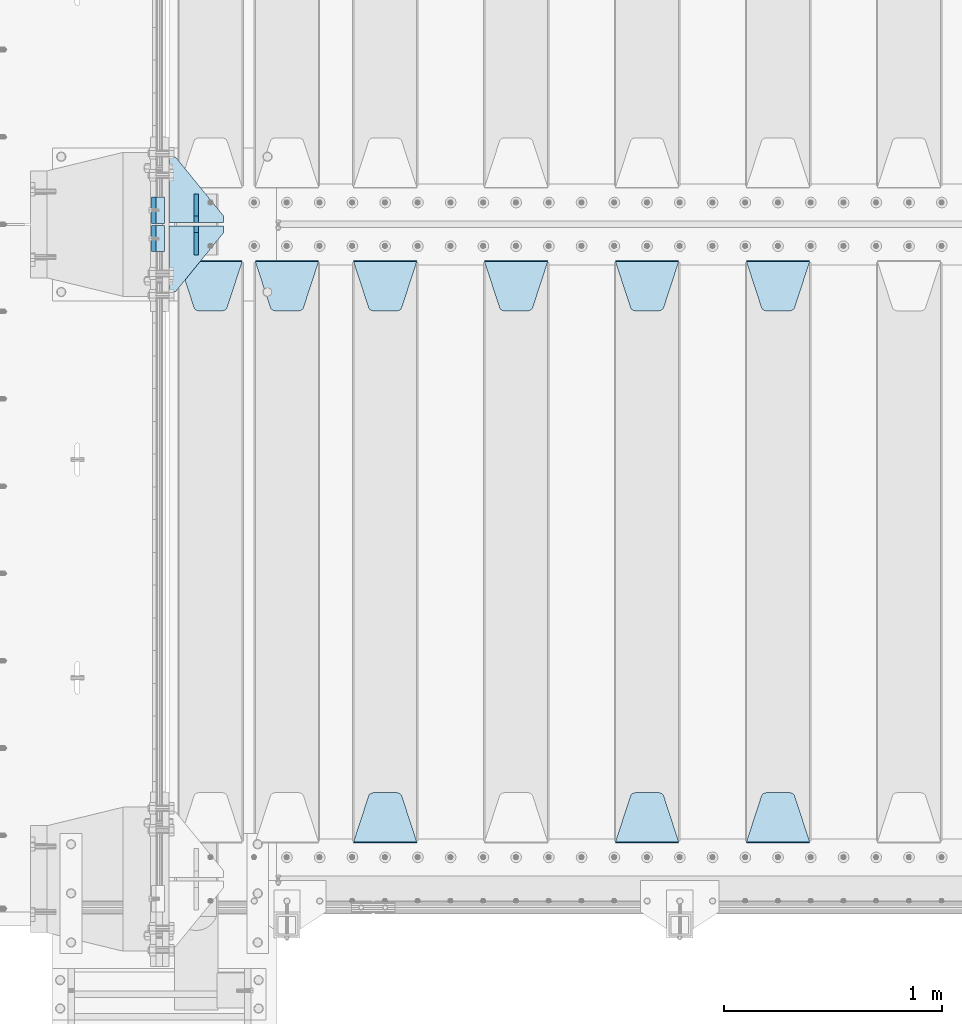
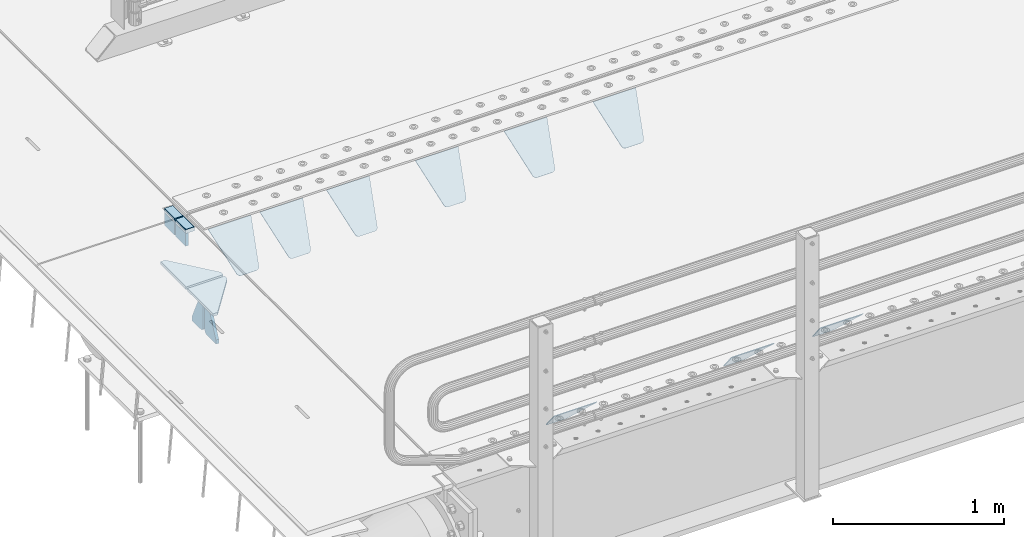
# One storey, part 196 of 242: 17 plates.
"""IFC2X3 building model written with IfcOpenShell, lengths in millimetres."""

from ifc_helpers import new_model, si_unit, frame, origin_with_axes, place, context, subcontext, project, spatial, faceted_brep, material, type_object, element, save


model = new_model("IFC2X3")

# Units and contexts
model_context = context("Model", 3, precision=1e-05, world=origin_with_axes())
body_context = subcontext(model_context, "Body", "Model", "MODEL_VIEW")
ifc_project = project(units=[si_unit("LENGTHUNIT", "METRE", prefix="MILLI"), si_unit("AREAUNIT", "SQUARE_METRE"), si_unit("VOLUMEUNIT", "CUBIC_METRE"), si_unit("MASSUNIT", "GRAM", prefix="KILO"), si_unit("TIMEUNIT", "SECOND"), si_unit("PLANEANGLEUNIT", "RADIAN"), si_unit("SOLIDANGLEUNIT", "STERADIAN"), si_unit("THERMODYNAMICTEMPERATUREUNIT", "DEGREE_CELSIUS"), si_unit("LUMINOUSINTENSITYUNIT", "LUMEN")], contexts=[model_context])

# Site, building, storey
site_placement = place(None, origin_with_axes())
site = spatial("IfcSite", under=ifc_project, at=site_placement, CompositionType="ELEMENT")
building_placement = place(site_placement, origin_with_axes())
building = spatial("IfcBuilding", under=site, at=building_placement, Name="Standard", CompositionType="ELEMENT")
storey_placement = place(building_placement, origin_with_axes())
storey = spatial("IfcBuildingStorey", under=building, at=storey_placement, Name="Undefined", CompositionType="ELEMENT", Elevation=0.0)

# Plates
ifc_material_1 = material()
plate_type_1 = type_object("IfcPlateType", PredefinedType="NOTDEFINED")
plate_1_placement = place(storey_placement, frame((-42460.0, -21064.9999999999, -16.0000763080354), z_axis=(-1.0, 0.0, 0.0), x_axis=(0.0, 0.0, 1.0)))
element("IfcPlate", 1, at=plate_1_placement, inside=storey, type_object=plate_type_1, material=ifc_material_1, context=body_context, shape_type="Brep", body=[
    faceted_brep([(-1.77635683940025e-15, -60.0, 0.0), (2.49929144047201e-09, -60.0000000000073, 60.0), (2.49928966411517e-09, 59.9999999999964, 60.0), (-1.77635683940025e-15, 60.0, -7.27595761418343e-12), (25.0146748218828, -60.0000000000073, 60.0), (25.0146748218828, 59.9999999999927, 60.0), (26.5597449794466, -60.0000000000073, 59.7552873949098), (26.5597449794466, 59.9999999999964, 59.7552873949098), (27.9535758796897, -60.0000000000036, 59.0451032832789), (27.9535758796897, 59.9999999999964, 59.0451032832789), (29.0597323263517, -60.0000000000073, 57.9389640667287), (29.0597323263517, 59.9999999999927, 57.9389640667287), (29.7699381491534, -60.0000000000073, 56.5451442289705), (29.7699381491534, 59.9999999999927, 56.5451442289705), (30.0146748212763, -60.0000000000073, 55.0000778834001), (30.0146748212763, 59.9999999999927, 55.0000778834001), (30.0154536553013, -60.0000000000036, 5.00007788340736), (30.0154536553013, 59.9999999999964, 5.00007788340736), (29.7707554908505, -60.0000000000073, 3.45497428546514), (29.7707554908505, 59.9999999999927, 3.45497428546514), (29.0605660948355, -60.0000000000073, 2.06111154406972), (29.0605660948355, 59.9999999999927, 2.06111154406972), (27.9544051209123, -60.0000000000036, 0.954933339693525), (27.9544051209123, 59.9999999999964, 0.954933339693525), (26.5605534420796, -60.0000000000073, 0.244722232011554), (26.5605534420796, 59.9999999999927, 0.244722232011554), (25.0154536559091, -60.0000000000073, 7.27595761418343e-12), (25.0154536559091, 59.9999999999927, 7.27595761418343e-12)], [[[0, 1, 2, 3]], [[1, 4, 5, 2]], [[4, 6, 7, 5]], [[6, 8, 9, 7]], [[8, 10, 11, 9]], [[10, 12, 13, 11]], [[12, 14, 15, 13]], [[14, 16, 17, 15]], [[16, 18, 19, 17]], [[18, 20, 21, 19]], [[20, 22, 23, 21]], [[22, 24, 25, 23]], [[24, 26, 27, 25]], [[26, 0, 3, 27]], [[5, 7, 9, 11, 13, 15, 17, 19, 21, 23, 25, 27, 3, 2]], [[26, 24, 22, 20, 18, 16, 14, 12, 10, 8, 6, 4, 1, 0]]]),
])
plate_2_placement = place(storey_placement, frame((-42460.0000000646, -20934.9999995679, -15.999743219274), z_axis=(-1.0, 0.0, 0.0), x_axis=(0.0, -4.95099997756316e-06, 0.999999999987744)))
element("IfcPlate", 2, at=plate_2_placement, inside=storey, type_object=plate_type_1, material=ifc_material_1, context=body_context, shape_type="Brep", body=[
    faceted_brep([(-1.77635683940025e-15, -60.0, 0.0), (-0.000933120085690575, -60.0, 60.0), (-0.000933120085690575, 60.0, 59.9999999999927), (-1.77635683940025e-15, 60.0, -7.27595761418343e-12), (24.9991450303709, -60.0, 60.0), (24.9991450303709, 60.0, 59.9999999999927), (26.544215218168, -60.0000000000036, 59.7552873850873), (26.544215218168, 60.0, 59.75528738508), (27.9380461396139, -60.0000000000036, 59.0451032459096), (27.9380461396139, 60.0, 59.0451032459096), (29.0442025908961, -60.0000000000036, 57.9389639895744), (29.0442025908961, 60.0, 57.9389639895744), (29.7544083969366, -60.0, 56.5451441080368), (29.7544083969366, 60.0, 56.5451441080295), (29.9991450297669, -60.0000000000036, 55.0000777244568), (29.9991450297669, 60.0, 55.0000777244495), (29.999922274335, -60.0, 5.00007772445679), (29.999922274335, 59.9999999999964, 5.00007772444951), (29.7552240705896, -60.0, 3.45497416452417), (29.7552240705896, 60.0000000000036, 3.45497416452417), (29.0450346578116, -60.0, 2.06111146690819), (29.0450346578116, 59.9999999999964, 2.06111146690819), (27.9388736885072, -60.0000000000036, 0.954933302316931), (27.9388736885072, 59.9999999999964, 0.954933302316931), (26.5450220308766, -60.0000000000036, 0.244722222181736), (26.5450220308766, 60.0, 0.244722222181736), (24.9999222749392, -60.0, 0.0), (24.9999222749392, 60.0, -7.27595761418343e-12)], [[[0, 1, 2, 3]], [[1, 4, 5, 2]], [[4, 6, 7, 5]], [[6, 8, 9, 7]], [[8, 10, 11, 9]], [[10, 12, 13, 11]], [[12, 14, 15, 13]], [[14, 16, 17, 15]], [[16, 18, 19, 17]], [[18, 20, 21, 19]], [[20, 22, 23, 21]], [[22, 24, 25, 23]], [[24, 26, 27, 25]], [[26, 0, 3, 27]], [[5, 7, 9, 11, 13, 15, 17, 19, 21, 23, 25, 27, 3, 2]], [[26, 24, 22, 20, 18, 16, 14, 12, 10, 8, 6, 4, 1, 0]]]),
])
ifc_material_2 = material(Name="STEEL/S355N")
plate_type_2 = type_object("IfcPlateType", PredefinedType="NOTDEFINED")
plate_3_placement = place(storey_placement, frame((-42510.0, -21004.9999144655, -105.984410846883), z_axis=(0.0, -1.0, 0.0), x_axis=(0.0, 0.0, 1.0)))
element("IfcPlate", 3, at=plate_3_placement, inside=storey, type_object=plate_type_2, material=ifc_material_2, context=body_context, shape_type="Brep", body=[
    faceted_brep([(0.0, -10.0, 0.0), (5.70725632087488e-07, -10.0, 120.0), (5.70725632087488e-07, 10.0, 120.0), (0.0, 10.0, 0.0), (89.9845046997066, -10.0, 120.000000000004), (89.9845046997066, 10.0, 120.000000000004), (89.9843902587891, -10.0, 6.91215973347425e-11), (89.9843902587891, 10.0, 6.91215973347425e-11)], [[[0, 1, 2, 3]], [[1, 4, 5, 2]], [[4, 6, 7, 5]], [[6, 0, 3, 7]], [[5, 7, 3, 2]], [[6, 4, 1, 0]]]),
])
plate_4_placement = place(storey_placement, frame((-42510.0, -20874.9995540189, -106.000068249326), z_axis=(1.0000003385235e-09, -0.999999999987744, -4.95099999993936e-06), x_axis=(0.0, -4.95099997756316e-06, 0.999999999987744)))
element("IfcPlate", 4, at=plate_4_placement, inside=storey, type_object=plate_type_2, material=ifc_material_2, context=body_context, shape_type="Brep", body=[
    faceted_brep([(0.0, -10.0, 0.0), (5.70725632087488e-07, -10.0, 120.0), (5.70725632087488e-07, 10.0, 120.0), (0.0, 10.0, 0.0), (89.9999999999979, -10.0, 120.000000000004), (89.9999999999979, 10.0, 120.000000000004), (90.0, -10.0, 1.09139364212751e-11), (90.0, 10.0, 1.09139364212751e-11)], [[[0, 1, 2, 3]], [[1, 4, 5, 2]], [[4, 6, 7, 5]], [[6, 0, 3, 7]], [[5, 7, 3, 2]], [[6, 4, 1, 0]]]),
])
plate_type_3 = type_object("IfcPlateType", PredefinedType="NOTDEFINED")
plate_5_placement = place(storey_placement, frame((-39795.0, -21168.232233044, -1.76776695296576), z_axis=(0.0, -0.707106781186547, -0.707106781186548), x_axis=(1.0, 0.0, 0.0)))
element("IfcPlate", 5, at=plate_5_placement, inside=storey, type_object=plate_type_3, material=ifc_material_2, context=body_context, shape_type="Brep", body=[
    faceted_brep([(0.0, -2.5, 0.0), (69.345504679477, -2.50000000000182, 300.171731424829), (69.345504679477, 2.5, 300.171731424829), (0.0, 2.5, 0.0), (70.9274061199576, -2.5, 304.897442415398), (70.9274061199576, 2.5, 304.897442415398), (73.3818627772307, -2.5, 309.234538108525), (73.3818627772307, 2.50000000000182, 309.234538108529), (76.6187032999551, -2.5, 313.023683126101), (76.6187032999551, 2.50000000000182, 313.023683126103), (80.5190132704993, -2.5, 316.12567259537), (80.5190132704993, 2.5, 316.12567259537), (84.9395038596849, -2.5, 318.426546230474), (84.9395038596849, 2.50000000000182, 318.426546230476), (89.7177759439219, -2.49999999999818, 319.841774983273), (89.7177759439219, 2.50000000000182, 319.841774983273), (94.678286292652, -2.5, 320.319366455076), (94.678286292652, 2.5, 320.319366455076), (195.321713707348, -2.5, 320.319366455076), (195.321713707348, 2.5, 320.319366455076), (200.282224056078, -2.5, 319.841774983272), (200.282224056078, 2.50000000000182, 319.841774983273), (205.060496140315, -2.5, 318.426546230474), (205.060496140315, 2.49999999999818, 318.426546230474), (209.480986729501, -2.49999999999818, 316.12567259537), (209.480986729501, 2.5, 316.12567259537), (213.381296700045, -2.5, 313.023683126101), (213.381296700045, 2.49999999999818, 313.023683126101), (216.618137222769, -2.5, 309.234538108525), (216.618137222769, 2.5, 309.234538108523), (219.072593880042, -2.49999999999818, 304.897442415398), (219.072593880042, 2.50000000000182, 304.897442415398), (220.654495320523, -2.50000000000182, 300.171731424829), (220.654495320523, 2.5, 300.171731424829), (290.0, -2.5, 0.0), (290.0, 2.5, -1.81898940354586e-12)], [[[0, 1, 2, 3]], [[1, 4, 5, 2]], [[4, 6, 7, 5]], [[6, 8, 9, 7]], [[8, 10, 11, 9]], [[10, 12, 13, 11]], [[12, 14, 15, 13]], [[14, 16, 17, 15]], [[16, 18, 19, 17]], [[18, 20, 21, 19]], [[20, 22, 23, 21]], [[22, 24, 25, 23]], [[24, 26, 27, 25]], [[26, 28, 29, 27]], [[28, 30, 31, 29]], [[30, 32, 33, 31]], [[32, 34, 35, 33]], [[34, 0, 3, 35]], [[5, 7, 9, 11, 13, 15, 17, 19, 21, 23, 25, 27, 29, 31, 33, 35, 3, 2]], [[34, 32, 30, 28, 26, 24, 22, 20, 18, 16, 14, 12, 10, 8, 6, 4, 1, 0]]]),
])
plate_6_placement = place(storey_placement, frame((-39505.0, -23831.767766953, -1.76776695296758), z_axis=(0.0, 0.707106781186547, -0.707106781186548), x_axis=(-1.0, 0.0, 0.0)))
element("IfcPlate", 6, at=plate_6_placement, inside=storey, type_object=plate_type_3, material=ifc_material_2, context=body_context, shape_type="Brep", body=[
    faceted_brep([(0.0, -2.5, 0.0), (69.345504679477, -2.50000000000182, 300.171731424829), (69.345504679477, 2.5, 300.171731424829), (0.0, 2.5, 0.0), (70.9274061199576, -2.5, 304.897442415398), (70.9274061199576, 2.5, 304.897442415398), (73.3818627772307, -2.5, 309.234538108525), (73.3818627772307, 2.50000000000182, 309.234538108529), (76.6187032999551, -2.5, 313.023683126101), (76.6187032999551, 2.50000000000182, 313.023683126103), (80.5190132704993, -2.5, 316.12567259537), (80.5190132704993, 2.5, 316.12567259537), (84.9395038596849, -2.5, 318.426546230474), (84.9395038596849, 2.50000000000182, 318.426546230476), (89.7177759439219, -2.49999999999818, 319.841774983273), (89.7177759439219, 2.50000000000182, 319.841774983273), (94.678286292652, -2.5, 320.319366455076), (94.678286292652, 2.5, 320.319366455076), (195.321713707348, -2.5, 320.319366455076), (195.321713707348, 2.5, 320.319366455076), (200.282224056078, -2.5, 319.841774983272), (200.282224056078, 2.50000000000182, 319.841774983273), (205.060496140315, -2.5, 318.426546230474), (205.060496140315, 2.49999999999818, 318.426546230474), (209.480986729501, -2.49999999999818, 316.12567259537), (209.480986729501, 2.5, 316.12567259537), (213.381296700045, -2.5, 313.023683126101), (213.381296700045, 2.49999999999818, 313.023683126101), (216.618137222769, -2.5, 309.234538108525), (216.618137222769, 2.5, 309.234538108523), (219.072593880042, -2.49999999999818, 304.897442415398), (219.072593880042, 2.50000000000182, 304.897442415398), (220.654495320523, -2.50000000000182, 300.171731424829), (220.654495320523, 2.5, 300.171731424829), (290.0, -2.5, 0.0), (290.0, 2.5, -1.81898940354586e-12)], [[[0, 1, 2, 3]], [[1, 4, 5, 2]], [[4, 6, 7, 5]], [[6, 8, 9, 7]], [[8, 10, 11, 9]], [[10, 12, 13, 11]], [[12, 14, 15, 13]], [[14, 16, 17, 15]], [[16, 18, 19, 17]], [[18, 20, 21, 19]], [[20, 22, 23, 21]], [[22, 24, 25, 23]], [[24, 26, 27, 25]], [[26, 28, 29, 27]], [[28, 30, 31, 29]], [[30, 32, 33, 31]], [[32, 34, 35, 33]], [[34, 0, 3, 35]], [[5, 7, 9, 11, 13, 15, 17, 19, 21, 23, 25, 27, 29, 31, 33, 35, 3, 2]], [[34, 32, 30, 28, 26, 24, 22, 20, 18, 16, 14, 12, 10, 8, 6, 4, 1, 0]]]),
])
plate_7_placement = place(storey_placement, frame((-40395.0, -21168.232233044, -1.76776695296576), z_axis=(0.0, -0.707106781186547, -0.707106781186548), x_axis=(1.0, 0.0, 0.0)))
element("IfcPlate", 7, at=plate_7_placement, inside=storey, type_object=plate_type_3, material=ifc_material_2, context=body_context, shape_type="Brep", body=[
    faceted_brep([(0.0, -2.5, 0.0), (69.345504679477, -2.50000000000182, 300.171731424829), (69.345504679477, 2.5, 300.171731424829), (0.0, 2.5, 0.0), (70.9274061199576, -2.5, 304.897442415398), (70.9274061199576, 2.5, 304.897442415398), (73.3818627772307, -2.5, 309.234538108525), (73.3818627772307, 2.50000000000182, 309.234538108529), (76.6187032999551, -2.5, 313.023683126101), (76.6187032999551, 2.50000000000182, 313.023683126103), (80.5190132704993, -2.5, 316.12567259537), (80.5190132704993, 2.5, 316.12567259537), (84.9395038596849, -2.5, 318.426546230474), (84.9395038596849, 2.50000000000182, 318.426546230476), (89.7177759439219, -2.49999999999818, 319.841774983273), (89.7177759439219, 2.50000000000182, 319.841774983273), (94.678286292652, -2.5, 320.319366455076), (94.678286292652, 2.5, 320.319366455076), (195.321713707348, -2.5, 320.319366455076), (195.321713707348, 2.5, 320.319366455076), (200.282224056078, -2.5, 319.841774983272), (200.282224056078, 2.50000000000182, 319.841774983273), (205.060496140315, -2.5, 318.426546230474), (205.060496140315, 2.49999999999818, 318.426546230474), (209.480986729501, -2.49999999999818, 316.12567259537), (209.480986729501, 2.5, 316.12567259537), (213.381296700045, -2.5, 313.023683126101), (213.381296700045, 2.49999999999818, 313.023683126101), (216.618137222769, -2.5, 309.234538108525), (216.618137222769, 2.5, 309.234538108523), (219.072593880042, -2.49999999999818, 304.897442415398), (219.072593880042, 2.50000000000182, 304.897442415398), (220.654495320523, -2.50000000000182, 300.171731424829), (220.654495320523, 2.5, 300.171731424829), (290.0, -2.5, 0.0), (290.0, 2.5, -1.81898940354586e-12)], [[[0, 1, 2, 3]], [[1, 4, 5, 2]], [[4, 6, 7, 5]], [[6, 8, 9, 7]], [[8, 10, 11, 9]], [[10, 12, 13, 11]], [[12, 14, 15, 13]], [[14, 16, 17, 15]], [[16, 18, 19, 17]], [[18, 20, 21, 19]], [[20, 22, 23, 21]], [[22, 24, 25, 23]], [[24, 26, 27, 25]], [[26, 28, 29, 27]], [[28, 30, 31, 29]], [[30, 32, 33, 31]], [[32, 34, 35, 33]], [[34, 0, 3, 35]], [[5, 7, 9, 11, 13, 15, 17, 19, 21, 23, 25, 27, 29, 31, 33, 35, 3, 2]], [[34, 32, 30, 28, 26, 24, 22, 20, 18, 16, 14, 12, 10, 8, 6, 4, 1, 0]]]),
])
plate_8_placement = place(storey_placement, frame((-40105.0, -23831.767766953, -1.76776695296758), z_axis=(0.0, 0.707106781186547, -0.707106781186548), x_axis=(-1.0, 0.0, 0.0)))
element("IfcPlate", 8, at=plate_8_placement, inside=storey, type_object=plate_type_3, material=ifc_material_2, context=body_context, shape_type="Brep", body=[
    faceted_brep([(0.0, -2.5, 0.0), (69.345504679477, -2.50000000000182, 300.171731424829), (69.345504679477, 2.5, 300.171731424829), (0.0, 2.5, 0.0), (70.9274061199576, -2.5, 304.897442415398), (70.9274061199576, 2.5, 304.897442415398), (73.3818627772307, -2.5, 309.234538108525), (73.3818627772307, 2.50000000000182, 309.234538108529), (76.6187032999551, -2.5, 313.023683126101), (76.6187032999551, 2.50000000000182, 313.023683126103), (80.5190132704993, -2.5, 316.12567259537), (80.5190132704993, 2.5, 316.12567259537), (84.9395038596849, -2.5, 318.426546230474), (84.9395038596849, 2.50000000000182, 318.426546230476), (89.7177759439219, -2.49999999999818, 319.841774983273), (89.7177759439219, 2.50000000000182, 319.841774983273), (94.678286292652, -2.5, 320.319366455076), (94.678286292652, 2.5, 320.319366455076), (195.321713707348, -2.5, 320.319366455076), (195.321713707348, 2.5, 320.319366455076), (200.282224056078, -2.5, 319.841774983272), (200.282224056078, 2.50000000000182, 319.841774983273), (205.060496140315, -2.5, 318.426546230474), (205.060496140315, 2.49999999999818, 318.426546230474), (209.480986729501, -2.49999999999818, 316.12567259537), (209.480986729501, 2.5, 316.12567259537), (213.381296700045, -2.5, 313.023683126101), (213.381296700045, 2.49999999999818, 313.023683126101), (216.618137222769, -2.5, 309.234538108525), (216.618137222769, 2.5, 309.234538108523), (219.072593880042, -2.49999999999818, 304.897442415398), (219.072593880042, 2.50000000000182, 304.897442415398), (220.654495320523, -2.50000000000182, 300.171731424829), (220.654495320523, 2.5, 300.171731424829), (290.0, -2.5, 0.0), (290.0, 2.5, -1.81898940354586e-12)], [[[0, 1, 2, 3]], [[1, 4, 5, 2]], [[4, 6, 7, 5]], [[6, 8, 9, 7]], [[8, 10, 11, 9]], [[10, 12, 13, 11]], [[12, 14, 15, 13]], [[14, 16, 17, 15]], [[16, 18, 19, 17]], [[18, 20, 21, 19]], [[20, 22, 23, 21]], [[22, 24, 25, 23]], [[24, 26, 27, 25]], [[26, 28, 29, 27]], [[28, 30, 31, 29]], [[30, 32, 33, 31]], [[32, 34, 35, 33]], [[34, 0, 3, 35]], [[5, 7, 9, 11, 13, 15, 17, 19, 21, 23, 25, 27, 29, 31, 33, 35, 3, 2]], [[34, 32, 30, 28, 26, 24, 22, 20, 18, 16, 14, 12, 10, 8, 6, 4, 1, 0]]]),
])
plate_9_placement = place(storey_placement, frame((-40995.0, -21168.232233044, -1.76776695296576), z_axis=(0.0, -0.707106781186547, -0.707106781186548), x_axis=(1.0, 0.0, 0.0)))
element("IfcPlate", 9, at=plate_9_placement, inside=storey, type_object=plate_type_3, material=ifc_material_2, context=body_context, shape_type="Brep", body=[
    faceted_brep([(0.0, -2.5, 0.0), (69.345504679477, -2.50000000000182, 300.171731424829), (69.345504679477, 2.5, 300.171731424829), (0.0, 2.5, 0.0), (70.9274061199576, -2.5, 304.897442415398), (70.9274061199576, 2.5, 304.897442415398), (73.3818627772307, -2.5, 309.234538108525), (73.3818627772307, 2.50000000000182, 309.234538108529), (76.6187032999551, -2.5, 313.023683126101), (76.6187032999551, 2.50000000000182, 313.023683126103), (80.5190132704993, -2.5, 316.12567259537), (80.5190132704993, 2.5, 316.12567259537), (84.9395038596849, -2.5, 318.426546230474), (84.9395038596849, 2.50000000000182, 318.426546230476), (89.7177759439219, -2.49999999999818, 319.841774983273), (89.7177759439219, 2.50000000000182, 319.841774983273), (94.678286292652, -2.5, 320.319366455076), (94.678286292652, 2.5, 320.319366455076), (195.321713707348, -2.5, 320.319366455076), (195.321713707348, 2.5, 320.319366455076), (200.282224056078, -2.5, 319.841774983272), (200.282224056078, 2.50000000000182, 319.841774983273), (205.060496140315, -2.5, 318.426546230474), (205.060496140315, 2.49999999999818, 318.426546230474), (209.480986729501, -2.49999999999818, 316.12567259537), (209.480986729501, 2.5, 316.12567259537), (213.381296700045, -2.5, 313.023683126101), (213.381296700045, 2.49999999999818, 313.023683126101), (216.618137222769, -2.5, 309.234538108525), (216.618137222769, 2.5, 309.234538108523), (219.072593880042, -2.49999999999818, 304.897442415398), (219.072593880042, 2.50000000000182, 304.897442415398), (220.654495320523, -2.50000000000182, 300.171731424829), (220.654495320523, 2.5, 300.171731424829), (290.0, -2.5, 0.0), (290.0, 2.5, -1.81898940354586e-12)], [[[0, 1, 2, 3]], [[1, 4, 5, 2]], [[4, 6, 7, 5]], [[6, 8, 9, 7]], [[8, 10, 11, 9]], [[10, 12, 13, 11]], [[12, 14, 15, 13]], [[14, 16, 17, 15]], [[16, 18, 19, 17]], [[18, 20, 21, 19]], [[20, 22, 23, 21]], [[22, 24, 25, 23]], [[24, 26, 27, 25]], [[26, 28, 29, 27]], [[28, 30, 31, 29]], [[30, 32, 33, 31]], [[32, 34, 35, 33]], [[34, 0, 3, 35]], [[5, 7, 9, 11, 13, 15, 17, 19, 21, 23, 25, 27, 29, 31, 33, 35, 3, 2]], [[34, 32, 30, 28, 26, 24, 22, 20, 18, 16, 14, 12, 10, 8, 6, 4, 1, 0]]]),
])
plate_10_placement = place(storey_placement, frame((-41595.0, -21168.232233044, -1.76776695296576), z_axis=(0.0, -0.707106781186547, -0.707106781186548), x_axis=(1.0, 0.0, 0.0)))
element("IfcPlate", 10, at=plate_10_placement, inside=storey, type_object=plate_type_3, material=ifc_material_2, context=body_context, shape_type="Brep", body=[
    faceted_brep([(0.0, -2.5, 0.0), (69.345504679477, -2.50000000000182, 300.171731424829), (69.345504679477, 2.5, 300.171731424829), (0.0, 2.5, 0.0), (70.9274061199576, -2.5, 304.897442415398), (70.9274061199576, 2.5, 304.897442415398), (73.3818627772307, -2.5, 309.234538108525), (73.3818627772307, 2.50000000000182, 309.234538108529), (76.6187032999551, -2.5, 313.023683126101), (76.6187032999551, 2.50000000000182, 313.023683126103), (80.5190132704993, -2.5, 316.12567259537), (80.5190132704993, 2.5, 316.12567259537), (84.9395038596849, -2.5, 318.426546230474), (84.9395038596849, 2.50000000000182, 318.426546230476), (89.7177759439219, -2.49999999999818, 319.841774983273), (89.7177759439219, 2.50000000000182, 319.841774983273), (94.678286292652, -2.5, 320.319366455076), (94.678286292652, 2.5, 320.319366455076), (195.321713707348, -2.5, 320.319366455076), (195.321713707348, 2.5, 320.319366455076), (200.282224056078, -2.5, 319.841774983272), (200.282224056078, 2.50000000000182, 319.841774983273), (205.060496140315, -2.5, 318.426546230474), (205.060496140315, 2.49999999999818, 318.426546230474), (209.480986729501, -2.49999999999818, 316.12567259537), (209.480986729501, 2.5, 316.12567259537), (213.381296700045, -2.5, 313.023683126101), (213.381296700045, 2.49999999999818, 313.023683126101), (216.618137222769, -2.5, 309.234538108525), (216.618137222769, 2.5, 309.234538108523), (219.072593880042, -2.49999999999818, 304.897442415398), (219.072593880042, 2.50000000000182, 304.897442415398), (220.654495320523, -2.50000000000182, 300.171731424829), (220.654495320523, 2.5, 300.171731424829), (290.0, -2.5, 0.0), (290.0, 2.5, -1.81898940354586e-12)], [[[0, 1, 2, 3]], [[1, 4, 5, 2]], [[4, 6, 7, 5]], [[6, 8, 9, 7]], [[8, 10, 11, 9]], [[10, 12, 13, 11]], [[12, 14, 15, 13]], [[14, 16, 17, 15]], [[16, 18, 19, 17]], [[18, 20, 21, 19]], [[20, 22, 23, 21]], [[22, 24, 25, 23]], [[24, 26, 27, 25]], [[26, 28, 29, 27]], [[28, 30, 31, 29]], [[30, 32, 33, 31]], [[32, 34, 35, 33]], [[34, 0, 3, 35]], [[5, 7, 9, 11, 13, 15, 17, 19, 21, 23, 25, 27, 29, 31, 33, 35, 3, 2]], [[34, 32, 30, 28, 26, 24, 22, 20, 18, 16, 14, 12, 10, 8, 6, 4, 1, 0]]]),
])
plate_11_placement = place(storey_placement, frame((-41305.0, -23831.767766953, -1.76776695296758), z_axis=(0.0, 0.707106781186547, -0.707106781186548), x_axis=(-1.0, 0.0, 0.0)))
element("IfcPlate", 11, at=plate_11_placement, inside=storey, type_object=plate_type_3, material=ifc_material_2, context=body_context, shape_type="Brep", body=[
    faceted_brep([(0.0, -2.5, 0.0), (69.345504679477, -2.50000000000182, 300.171731424829), (69.345504679477, 2.5, 300.171731424829), (0.0, 2.5, 0.0), (70.9274061199576, -2.5, 304.897442415398), (70.9274061199576, 2.5, 304.897442415398), (73.3818627772307, -2.5, 309.234538108525), (73.3818627772307, 2.50000000000182, 309.234538108529), (76.6187032999551, -2.5, 313.023683126101), (76.6187032999551, 2.50000000000182, 313.023683126103), (80.5190132704993, -2.5, 316.12567259537), (80.5190132704993, 2.5, 316.12567259537), (84.9395038596849, -2.5, 318.426546230474), (84.9395038596849, 2.50000000000182, 318.426546230476), (89.7177759439219, -2.49999999999818, 319.841774983273), (89.7177759439219, 2.50000000000182, 319.841774983273), (94.678286292652, -2.5, 320.319366455076), (94.678286292652, 2.5, 320.319366455076), (195.321713707348, -2.5, 320.319366455076), (195.321713707348, 2.5, 320.319366455076), (200.282224056078, -2.5, 319.841774983272), (200.282224056078, 2.50000000000182, 319.841774983273), (205.060496140315, -2.5, 318.426546230474), (205.060496140315, 2.49999999999818, 318.426546230474), (209.480986729501, -2.49999999999818, 316.12567259537), (209.480986729501, 2.5, 316.12567259537), (213.381296700045, -2.5, 313.023683126101), (213.381296700045, 2.49999999999818, 313.023683126101), (216.618137222769, -2.5, 309.234538108525), (216.618137222769, 2.5, 309.234538108523), (219.072593880042, -2.49999999999818, 304.897442415398), (219.072593880042, 2.50000000000182, 304.897442415398), (220.654495320523, -2.50000000000182, 300.171731424829), (220.654495320523, 2.5, 300.171731424829), (290.0, -2.5, 0.0), (290.0, 2.5, -1.81898940354586e-12)], [[[0, 1, 2, 3]], [[1, 4, 5, 2]], [[4, 6, 7, 5]], [[6, 8, 9, 7]], [[8, 10, 11, 9]], [[10, 12, 13, 11]], [[12, 14, 15, 13]], [[14, 16, 17, 15]], [[16, 18, 19, 17]], [[18, 20, 21, 19]], [[20, 22, 23, 21]], [[22, 24, 25, 23]], [[24, 26, 27, 25]], [[26, 28, 29, 27]], [[28, 30, 31, 29]], [[30, 32, 33, 31]], [[32, 34, 35, 33]], [[34, 0, 3, 35]], [[5, 7, 9, 11, 13, 15, 17, 19, 21, 23, 25, 27, 29, 31, 33, 35, 3, 2]], [[34, 32, 30, 28, 26, 24, 22, 20, 18, 16, 14, 12, 10, 8, 6, 4, 1, 0]]]),
])
plate_12_placement = place(storey_placement, frame((-42045.0, -21168.232233044, -1.76776695296576), z_axis=(0.0, -0.707106781186547, -0.707106781186548), x_axis=(1.0, 0.0, 0.0)))
element("IfcPlate", 12, at=plate_12_placement, inside=storey, type_object=plate_type_3, material=ifc_material_2, context=body_context, shape_type="Brep", body=[
    faceted_brep([(0.0, -2.5, 0.0), (69.345504679477, -2.50000000000182, 300.171731424829), (69.345504679477, 2.5, 300.171731424829), (0.0, 2.5, 0.0), (70.9274061199576, -2.5, 304.897442415398), (70.9274061199576, 2.5, 304.897442415398), (73.3818627772307, -2.5, 309.234538108525), (73.3818627772307, 2.50000000000182, 309.234538108529), (76.6187032999551, -2.5, 313.023683126101), (76.6187032999551, 2.50000000000182, 313.023683126103), (80.5190132704993, -2.5, 316.12567259537), (80.5190132704993, 2.5, 316.12567259537), (84.9395038596849, -2.5, 318.426546230474), (84.9395038596849, 2.50000000000182, 318.426546230476), (89.7177759439219, -2.49999999999818, 319.841774983273), (89.7177759439219, 2.50000000000182, 319.841774983273), (94.678286292652, -2.5, 320.319366455076), (94.678286292652, 2.5, 320.319366455076), (195.321713707348, -2.5, 320.319366455076), (195.321713707348, 2.5, 320.319366455076), (200.282224056078, -2.5, 319.841774983272), (200.282224056078, 2.50000000000182, 319.841774983273), (205.060496140315, -2.5, 318.426546230474), (205.060496140315, 2.49999999999818, 318.426546230474), (209.480986729501, -2.49999999999818, 316.12567259537), (209.480986729501, 2.5, 316.12567259537), (213.381296700045, -2.5, 313.023683126101), (213.381296700045, 2.49999999999818, 313.023683126101), (216.618137222769, -2.5, 309.234538108525), (216.618137222769, 2.5, 309.234538108523), (219.072593880042, -2.49999999999818, 304.897442415398), (219.072593880042, 2.50000000000182, 304.897442415398), (220.654495320523, -2.50000000000182, 300.171731424829), (220.654495320523, 2.5, 300.171731424829), (290.0, -2.5, 0.0), (290.0, 2.5, -1.81898940354586e-12)], [[[0, 1, 2, 3]], [[1, 4, 5, 2]], [[4, 6, 7, 5]], [[6, 8, 9, 7]], [[8, 10, 11, 9]], [[10, 12, 13, 11]], [[12, 14, 15, 13]], [[14, 16, 17, 15]], [[16, 18, 19, 17]], [[18, 20, 21, 19]], [[20, 22, 23, 21]], [[22, 24, 25, 23]], [[24, 26, 27, 25]], [[26, 28, 29, 27]], [[28, 30, 31, 29]], [[30, 32, 33, 31]], [[32, 34, 35, 33]], [[34, 0, 3, 35]], [[5, 7, 9, 11, 13, 15, 17, 19, 21, 23, 25, 27, 29, 31, 33, 35, 3, 2]], [[34, 32, 30, 28, 26, 24, 22, 20, 18, 16, 14, 12, 10, 8, 6, 4, 1, 0]]]),
])
plate_13_placement = place(storey_placement, frame((-42395.0, -21168.232233044, -1.76776695296576), z_axis=(0.0, -0.707106781186547, -0.707106781186548), x_axis=(1.0, 0.0, 0.0)))
element("IfcPlate", 13, at=plate_13_placement, inside=storey, type_object=plate_type_3, material=ifc_material_2, context=body_context, shape_type="Brep", body=[
    faceted_brep([(0.0, -2.5, 0.0), (69.345504679477, -2.50000000000182, 300.171731424829), (69.345504679477, 2.5, 300.171731424829), (0.0, 2.5, 0.0), (70.9274061199576, -2.5, 304.897442415398), (70.9274061199576, 2.5, 304.897442415398), (73.3818627772307, -2.5, 309.234538108525), (73.3818627772307, 2.50000000000182, 309.234538108529), (76.6187032999551, -2.5, 313.023683126101), (76.6187032999551, 2.50000000000182, 313.023683126103), (80.5190132704993, -2.5, 316.12567259537), (80.5190132704993, 2.5, 316.12567259537), (84.9395038596849, -2.5, 318.426546230474), (84.9395038596849, 2.50000000000182, 318.426546230476), (89.7177759439219, -2.49999999999818, 319.841774983273), (89.7177759439219, 2.50000000000182, 319.841774983273), (94.678286292652, -2.5, 320.319366455076), (94.678286292652, 2.5, 320.319366455076), (195.321713707348, -2.5, 320.319366455076), (195.321713707348, 2.5, 320.319366455076), (200.282224056078, -2.5, 319.841774983272), (200.282224056078, 2.50000000000182, 319.841774983273), (205.060496140315, -2.5, 318.426546230474), (205.060496140315, 2.49999999999818, 318.426546230474), (209.480986729501, -2.49999999999818, 316.12567259537), (209.480986729501, 2.5, 316.12567259537), (213.381296700045, -2.5, 313.023683126101), (213.381296700045, 2.49999999999818, 313.023683126101), (216.618137222769, -2.5, 309.234538108525), (216.618137222769, 2.5, 309.234538108523), (219.072593880042, -2.49999999999818, 304.897442415398), (219.072593880042, 2.50000000000182, 304.897442415398), (220.654495320523, -2.50000000000182, 300.171731424829), (220.654495320523, 2.5, 300.171731424829), (290.0, -2.5, 0.0), (290.0, 2.5, -1.81898940354586e-12)], [[[0, 1, 2, 3]], [[1, 4, 5, 2]], [[4, 6, 7, 5]], [[6, 8, 9, 7]], [[8, 10, 11, 9]], [[10, 12, 13, 11]], [[12, 14, 15, 13]], [[14, 16, 17, 15]], [[16, 18, 19, 17]], [[18, 20, 21, 19]], [[20, 22, 23, 21]], [[22, 24, 25, 23]], [[24, 26, 27, 25]], [[26, 28, 29, 27]], [[28, 30, 31, 29]], [[30, 32, 33, 31]], [[32, 34, 35, 33]], [[34, 0, 3, 35]], [[5, 7, 9, 11, 13, 15, 17, 19, 21, 23, 25, 27, 29, 31, 33, 35, 3, 2]], [[34, 32, 30, 28, 26, 24, 22, 20, 18, 16, 14, 12, 10, 8, 6, 4, 1, 0]]]),
])
plate_type_4 = type_object("IfcPlateType", PredefinedType="NOTDEFINED")
for number, where, z_axis, x_axis in (
    (14, (-42190.0, -20992.0, -515.0), (0.0, 1.0, 0.0), (-1.0, 0.0, 0.0)),
    (15, (-42190.0, -21008.0, -515.0), (0.0, -1.0, 0.0), (-1.0, 0.0, 0.0)),
):
    element("IfcPlate", number, at=place(storey_placement, frame(where, z_axis=z_axis, x_axis=x_axis)), inside=storey, type_object=plate_type_4, material=ifc_material_2, context=body_context, shape_type="Brep", body=[
        faceted_brep([(0.0, -10.0, 0.0), (0.0, -10.0, 30.0), (0.0, 10.0, 30.0), (0.0, 10.0, 0.0), (220.0, -10.0, 300.0), (220.0, 10.0, 300.0), (250.0, -10.0, 300.0), (250.0, 10.0, 300.0), (250.0, -10.0, 0.0), (250.0, 10.0, 0.0)], [[[0, 1, 2, 3]], [[1, 4, 5, 2]], [[4, 6, 7, 5]], [[6, 8, 9, 7]], [[8, 0, 3, 9]], [[5, 7, 9, 3, 2]], [[8, 6, 4, 1, 0]]]),
    ])
plate_type_5 = type_object("IfcPlateType", PredefinedType="NOTDEFINED")
for number, where, z_axis, x_axis in (
    (16, (-42315.0, -20860.0, -865.0), (0.0, 0.0, 1.0), (0.0, -1.0, 0.0)),
    (17, (-42315.0, -21140.0, -865.0), (0.0, 0.0, 1.0), (0.0, 1.0, 0.0)),
):
    element("IfcPlate", number, at=place(storey_placement, frame(where, z_axis=z_axis, x_axis=x_axis)), inside=storey, type_object=plate_type_5, material=ifc_material_2, context=body_context, shape_type="Brep", body=[
        faceted_brep([(0.0, -10.0, 0.0), (0.0, -10.0, 30.0), (0.0, 10.0, 30.0), (0.0, 10.0, 0.0), (102.0, -10.0, 250.0), (102.0, 10.0, 250.0), (132.0, -10.0, 250.0), (132.0, 10.0, 250.0), (132.0, -10.0, 30.0), (132.0, 10.0, 30.0), (131.544232590368, -10.0, 24.790554669992), (131.544232590368, 10.0, 24.790554669992), (130.190778623579, -10.0, 19.7393957002299), (130.190778623579, 10.0, 19.7393957002299), (127.980762113533, -10.0, 15.0), (127.980762113533, 10.0, 15.0), (124.98133329357, -10.0, 10.7163717094038), (124.98133329357, 10.0, 10.7163717094038), (121.283628290596, -10.0, 7.01866670643062), (121.283628290596, 10.0, 7.01866670643062), (117.0, -10.0, 4.01923788646684), (117.0, 10.0, 4.01923788646684), (112.260604299769, -10.0, 1.80922137642278), (112.260604299769, 10.0, 1.80922137642278), (107.209445330009, -10.0, 0.455767409633722), (107.209445330009, 10.0, 0.455767409633722), (102.0, -10.0, 0.0), (102.0, 10.0, 0.0)], [[[0, 1, 2, 3]], [[1, 4, 5, 2]], [[4, 6, 7, 5]], [[6, 8, 9, 7]], [[8, 10, 11, 9]], [[10, 12, 13, 11]], [[12, 14, 15, 13]], [[14, 16, 17, 15]], [[16, 18, 19, 17]], [[18, 20, 21, 19]], [[20, 22, 23, 21]], [[22, 24, 25, 23]], [[24, 26, 27, 25]], [[26, 0, 3, 27]], [[5, 7, 9, 11, 13, 15, 17, 19, 21, 23, 25, 27, 3, 2]], [[26, 24, 22, 20, 18, 16, 14, 12, 10, 8, 6, 4, 1, 0]]]),
    ])

save(model, "model.ifc")
